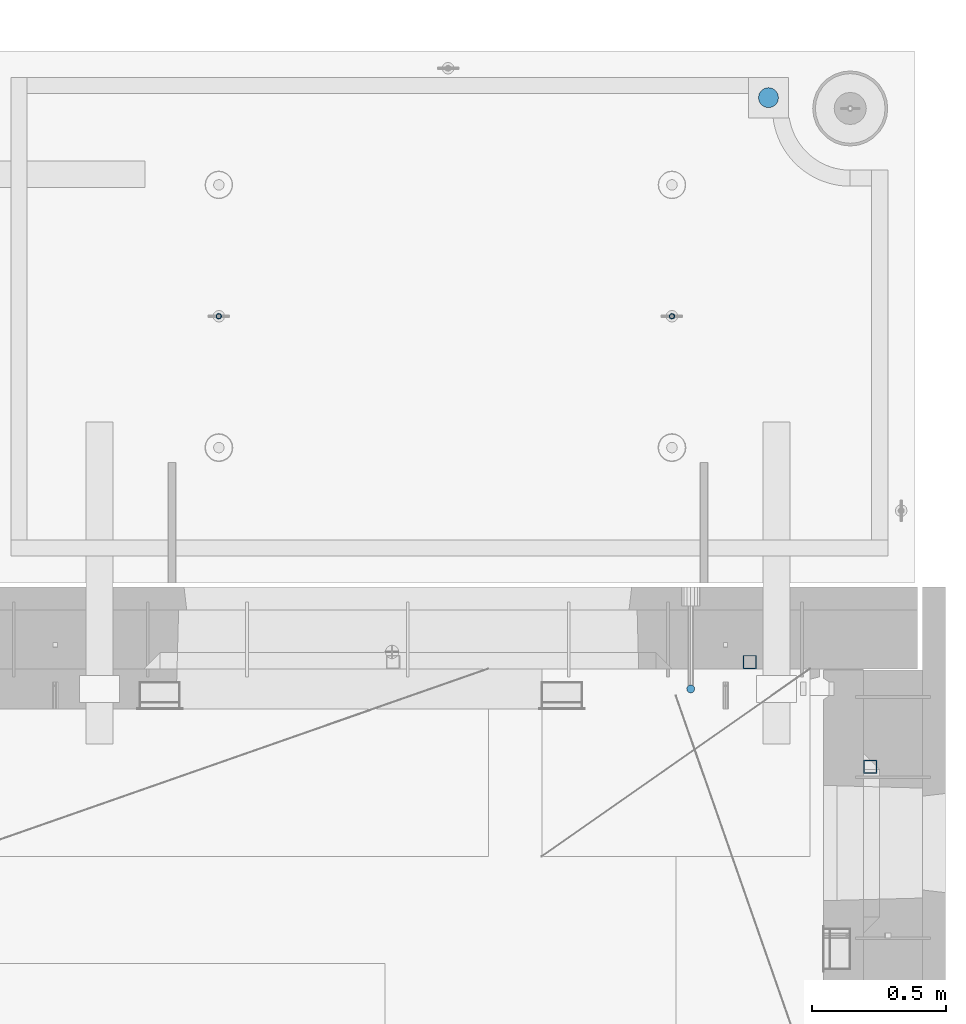
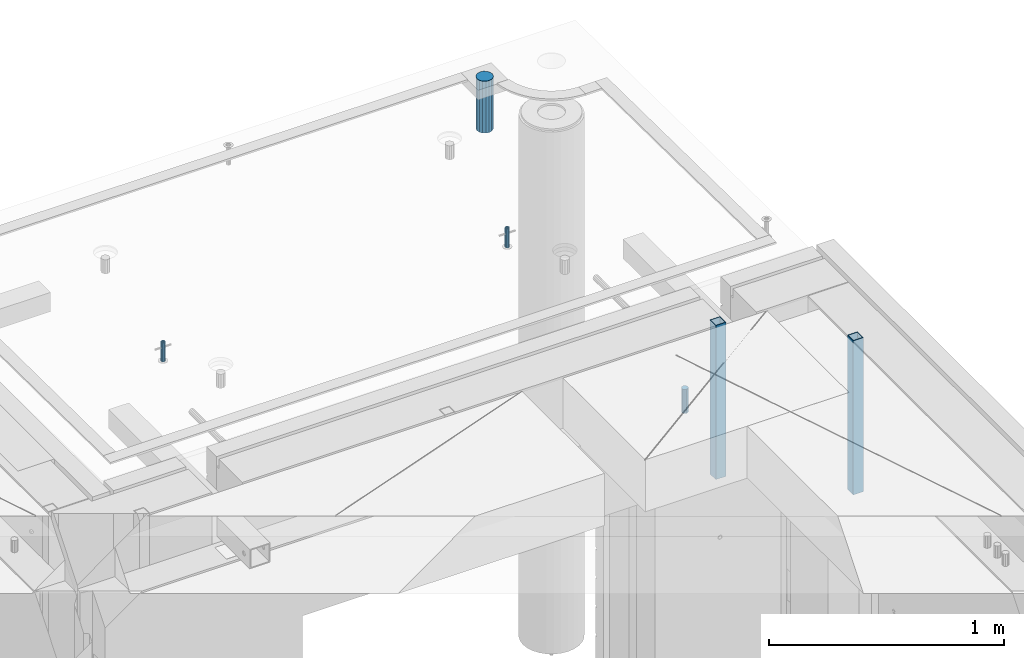
# One storey, part 35 of 334: 6 columns, 7 elements without a shape of their own.
"""IFC2X3 building model written with IfcOpenShell, lengths in millimetres."""

from ifc_helpers import new_model, si_unit, frame, origin_with_axes, place, context, subcontext, project, spatial, faceted_brep, material, type_object, element, aggregate, save


model = new_model("IFC2X3")

# Units and contexts
model_context = context("Model", 3, precision=1e-05, world=origin_with_axes())
body_context = subcontext(model_context, "Body", "Model", "MODEL_VIEW")
ifc_project = project(units=[si_unit("LENGTHUNIT", "METRE", prefix="MILLI"), si_unit("AREAUNIT", "SQUARE_METRE"), si_unit("VOLUMEUNIT", "CUBIC_METRE"), si_unit("MASSUNIT", "GRAM", prefix="KILO"), si_unit("TIMEUNIT", "SECOND"), si_unit("PLANEANGLEUNIT", "RADIAN"), si_unit("SOLIDANGLEUNIT", "STERADIAN"), si_unit("THERMODYNAMICTEMPERATUREUNIT", "DEGREE_CELSIUS"), si_unit("LUMINOUSINTENSITYUNIT", "LUMEN")], contexts=[model_context])

# Site, building, storey
site_placement = place(None, origin_with_axes())
site = spatial("IfcSite", under=ifc_project, at=site_placement, CompositionType="ELEMENT")
building_placement = place(site_placement, origin_with_axes())
building = spatial("IfcBuilding", under=site, at=building_placement, CompositionType="ELEMENT")
storey_placement = place(building_placement, origin_with_axes())
storey = spatial("IfcBuildingStorey", under=building, at=storey_placement, Name="3", CompositionType="ELEMENT", Elevation=0.0)

# Assemblies, columns
assembly_1_placement = place(storey_placement, origin_with_axes())
assembly_1 = element("IfcElementAssembly", 1, at=assembly_1_placement, inside=storey, AssemblyPlace="NOTDEFINED", PredefinedType="REINFORCEMENT_UNIT")
ifc_material_1 = material()
column_type_1 = type_object("IfcColumnType", Name="D30", PredefinedType="NOTDEFINED")
column_1_placement = place(assembly_1_placement, frame((34415.0073334623, 20504.9951872205, 90407.5), z_axis=(0.0, -1.0, 0.0), x_axis=(0.0, 0.0, 1.0)))
column_1 = element("IfcColumn", 2, at=column_1_placement, type_object=column_type_1, material=ifc_material_1, ObjectType="D30", context=body_context, shape_type="Brep", body=[
    faceted_brep([(0.0, -15.0, 0.0), (0.0, -12.9903810567666, -7.5), (125.0, -12.9903810567666, -7.5), (125.0, -15.0, 0.0), (0.0, -7.5, -12.9903810567666), (125.0, -7.5, -12.9903810567666), (0.0, 0.0, -15.0), (125.0, 0.0, -15.0), (0.0, 7.5, -12.9903810567666), (125.0, 7.5, -12.9903810567666), (0.0, 12.9903810567666, -7.5), (125.0, 12.9903810567666, -7.5), (0.0, 15.0, 0.0), (125.0, 15.0, 0.0), (0.0, 12.9903810567666, 7.5), (125.0, 12.9903810567666, 7.5), (0.0, 7.5, 12.9903810567666), (125.0, 7.5, 12.9903810567666), (0.0, 0.0, 15.0), (125.0, 0.0, 15.0), (0.0, -7.5, 12.9903810567666), (125.0, -7.5, 12.9903810567666), (0.0, -12.9903810567666, 7.5), (125.0, -12.9903810567666, 7.5)], [[[0, 1, 2, 3]], [[1, 4, 5, 2]], [[4, 6, 7, 5]], [[6, 8, 9, 7]], [[8, 10, 11, 9]], [[10, 12, 13, 11]], [[12, 14, 15, 13]], [[14, 16, 17, 15]], [[16, 18, 19, 17]], [[18, 20, 21, 19]], [[20, 22, 23, 21]], [[22, 0, 3, 23]], [[5, 7, 9, 11, 13, 15, 17, 19, 21, 23, 3, 2]], [[22, 20, 18, 16, 14, 12, 10, 8, 6, 4, 1, 0]]]),
])
assembly_2_placement = place(assembly_1_placement, origin_with_axes())
assembly_2 = element("IfcElementAssembly", 3, at=assembly_2_placement, Name="Steel Assembly", AssemblyPlace="NOTDEFINED", PredefinedType="RIGID_FRAME")
aggregate(assembly_1, [assembly_2, column_1])
ifc_material_2 = material(Name="STEEL/S355J2")
column_type_2 = type_object("IfcColumnType", Name="50X50X3", PredefinedType="NOTDEFINED")
column_2_placement = place(assembly_2_placement, frame((34635.0, 20605.0, 89940.0), z_axis=(1.0, 0.0, 0.0), x_axis=(0.0, 0.0, 1.0)))
column_2 = element("IfcColumn", 4, at=column_2_placement, type_object=column_type_2, material=ifc_material_2, ObjectType="50X50X3", context=body_context, shape_type="Brep", body=[
    faceted_brep([(0.0, 22.0, -22.0), (0.0, -22.0, -22.0), (800.0, -22.0, -22.0), (800.0, 22.0, -22.0), (0.0, -22.0, 22.0), (800.0, -22.0, 22.0), (0.0, 22.0, 22.0), (800.0, 22.0, 22.0), (0.0, 25.0, -25.0), (0.0, 25.0, 25.0), (800.0, 25.0, 25.0), (800.0, 25.0, -25.0), (0.0, -25.0, 25.0), (800.0, -25.0, 25.0), (0.0, -25.0, -25.0), (800.0, -25.0, -25.0)], [[[0, 1, 2, 3]], [[1, 4, 5, 2]], [[4, 6, 7, 5]], [[6, 0, 3, 7]], [[8, 9, 10, 11]], [[9, 12, 13, 10]], [[12, 14, 15, 13]], [[14, 8, 11, 15]], [[13, 15, 11, 10], [5, 7, 3, 2]], [[14, 12, 9, 8], [6, 4, 1, 0]]]),
])
aggregate(assembly_2, [column_2])

# Assemblies, column
assembly_3_placement = place(storey_placement, origin_with_axes())
assembly_3 = element("IfcElementAssembly", 5, at=assembly_3_placement, inside=storey, AssemblyPlace="NOTDEFINED", PredefinedType="REINFORCEMENT_UNIT")
assembly_4_placement = place(assembly_3_placement, origin_with_axes())
assembly_4 = element("IfcElementAssembly", 6, at=assembly_4_placement, Name="Steel Assembly", AssemblyPlace="NOTDEFINED", PredefinedType="RIGID_FRAME")
aggregate(assembly_3, [assembly_4])
column_3_placement = place(assembly_4_placement, frame((35085.0, 20215.0002861023, 89940.0), z_axis=(0.0, -1.0, 0.0), x_axis=(0.0, 0.0, 1.0)))
column_3 = element("IfcColumn", 7, at=column_3_placement, type_object=column_type_2, material=ifc_material_2, ObjectType="50X50X3", context=body_context, shape_type="Brep", body=[
    faceted_brep([(0.0, 22.0, -22.0), (0.0, -22.0, -22.0), (800.0, -22.0, -22.0), (800.0, 22.0, -22.0), (0.0, -22.0, 22.0), (800.0, -22.0, 22.0), (0.0, 22.0, 22.0), (800.0, 22.0, 22.0), (0.0, 25.0, -25.0), (0.0, 25.0, 25.0), (800.0, 25.0, 25.0), (800.0, 25.0, -25.0), (0.0, -25.0, 25.0), (800.0, -25.0, 25.0), (0.0, -25.0, -25.0), (800.0, -25.0, -25.0)], [[[0, 1, 2, 3]], [[1, 4, 5, 2]], [[4, 6, 7, 5]], [[6, 0, 3, 7]], [[8, 9, 10, 11]], [[9, 12, 13, 10]], [[12, 14, 15, 13]], [[14, 8, 11, 15]], [[13, 15, 11, 10], [5, 7, 3, 2]], [[14, 12, 9, 8], [6, 4, 1, 0]]]),
])
aggregate(assembly_4, [column_3])

# Assemblies, columns
assembly_5_placement = place(storey_placement, origin_with_axes())
assembly_5 = element("IfcElementAssembly", 8, at=assembly_5_placement, inside=storey, AssemblyPlace="NOTDEFINED", PredefinedType="REINFORCEMENT_UNIT")
assembly_6_placement = place(assembly_5_placement, origin_with_axes())
assembly_6 = element("IfcElementAssembly", 9, at=assembly_6_placement, Name="Steel Assembly", AssemblyPlace="NOTDEFINED", PredefinedType="RIGID_FRAME")
ifc_material_3 = material(Name="STEEL/1.4301")
column_type_3 = type_object("IfcColumnType", PredefinedType="NOTDEFINED")
column_4_placement = place(assembly_6_placement, frame((32654.9901431868, 21895.0034426477, 90445.0), z_axis=(0.000321686000089053, -0.999999948259057, 0.0), x_axis=(0.0, 0.0, 1.0)))
column_4 = element("IfcColumn", 10, at=column_4_placement, type_object=column_type_3, material=ifc_material_3, context=body_context, shape_type="Brep", body=[
    faceted_brep([(0.0, -8.0, 0.0), (0.0, -6.92820323027263, 4.0), (100.000000000029, -6.92820323027263, 4.0), (100.000000000029, -7.99999999999636, 0.0), (0.0, -4.0, 6.92820323027627), (100.000000000029, -4.0, 6.92820323027536), (0.0, 0.0, 8.0), (100.000000000029, 3.63797880709171e-12, 8.0), (0.0, 4.0, 6.92820323027627), (100.000000000029, 4.0, 6.92820323027536), (0.0, 6.92820323027263, 4.0), (100.000000000029, 6.92820323027627, 3.99999999999909), (0.0, 8.0, 0.0), (100.000000000029, 8.0, 0.0), (0.0, 6.92820323027263, -4.0), (100.000000000029, 6.92820323027627, -4.00000000000091), (0.0, 4.0, -6.92820323027627), (100.000000000029, 4.00000000000364, -6.92820323027536), (0.0, 0.0, -8.0), (100.000000000029, 3.63797880709171e-12, -8.00000000000091), (0.0, -4.0, -6.92820323027627), (100.000000000029, -3.99999999999636, -6.92820323027627), (0.0, -6.92820323027263, -4.0), (100.000000000029, -6.92820323027263, -4.0), (0.0, -10.4999999999927, -1.45519152283669e-11), (0.0, -9.09326673972828, -5.25000000001455), (100.000000000262, -9.09326673972828, -5.25000000001455), (100.000000000262, -10.4999999999927, -1.45519152283669e-11), (0.0, -5.24999999998545, -9.09326673974283), (100.000000000262, -5.24999999998545, -9.09326673974283), (0.0, 7.27595761418343e-12, -10.5), (100.000000000262, 7.27595761418343e-12, -10.5), (0.0, 5.25000000001455, -9.09326673975738), (100.000000000262, 5.25000000001455, -9.09326673975738), (0.0, 9.09326673975011, -5.25000000001455), (100.000000000262, 9.09326673975011, -5.25000000001455), (0.0, 10.5000000000073, -1.45519152283669e-11), (100.000000000262, 10.5000000000073, -1.45519152283669e-11), (0.0, 9.09326673975011, 5.25), (100.000000000262, 9.09326673975011, 5.25), (0.0, 5.25000000000728, 9.09326673972828), (100.000000000262, 5.25000000000728, 9.09326673972828), (0.0, 1.45519152283669e-11, 10.4999999999854), (100.000000000262, 1.45519152283669e-11, 10.4999999999854), (0.0, -5.24999999999272, 9.09326673972828), (100.000000000262, -5.24999999999272, 9.09326673972828), (0.0, -9.09326673972828, 5.24999999998545), (100.000000000262, -9.09326673972828, 5.24999999998545)], [[[0, 1, 2, 3]], [[1, 4, 5, 2]], [[4, 6, 7, 5]], [[6, 8, 9, 7]], [[8, 10, 11, 9]], [[10, 12, 13, 11]], [[12, 14, 15, 13]], [[14, 16, 17, 15]], [[16, 18, 19, 17]], [[18, 20, 21, 19]], [[20, 22, 23, 21]], [[22, 0, 3, 23]], [[24, 25, 26, 27]], [[25, 28, 29, 26]], [[28, 30, 31, 29]], [[30, 32, 33, 31]], [[32, 34, 35, 33]], [[34, 36, 37, 35]], [[36, 38, 39, 37]], [[38, 40, 41, 39]], [[40, 42, 43, 41]], [[42, 44, 45, 43]], [[44, 46, 47, 45]], [[46, 24, 27, 47]], [[29, 31, 33, 35, 37, 39, 41, 43, 45, 47, 27, 26], [5, 7, 9, 11, 13, 15, 17, 19, 21, 23, 3, 2]], [[46, 44, 42, 40, 38, 36, 34, 32, 30, 28, 25, 24], [22, 20, 18, 16, 14, 12, 10, 8, 6, 4, 1, 0]]]),
])
aggregate(assembly_6, [column_4])
assembly_7_placement = place(assembly_5_placement, origin_with_axes())
assembly_7 = element("IfcElementAssembly", 11, at=assembly_7_placement, Name="Steel Assembly", AssemblyPlace="NOTDEFINED", PredefinedType="RIGID_FRAME")
column_5_placement = place(assembly_7_placement, frame((34345.0001431868, 21895.0034426477, 90445.0), z_axis=(0.000321686000089053, -0.999999948259057, 0.0), x_axis=(0.0, 0.0, 1.0)))
column_5 = element("IfcColumn", 12, at=column_5_placement, type_object=column_type_3, material=ifc_material_3, context=body_context, shape_type="Brep", body=[
    faceted_brep([(0.0, -8.0, 0.0), (0.0, -6.92820323027263, 4.0), (100.000000000029, -6.92820323027263, 4.0), (100.000000000029, -7.99999999999636, 0.0), (0.0, -4.0, 6.92820323027627), (100.000000000029, -4.0, 6.92820323027536), (0.0, 0.0, 8.0), (100.000000000029, 3.63797880709171e-12, 8.0), (0.0, 4.0, 6.92820323027627), (100.000000000029, 4.0, 6.92820323027536), (0.0, 6.92820323027263, 4.0), (100.000000000029, 6.92820323027627, 3.99999999999909), (0.0, 8.0, 0.0), (100.000000000029, 8.0, 0.0), (0.0, 6.92820323027263, -4.0), (100.000000000029, 6.92820323027627, -4.00000000000091), (0.0, 4.0, -6.92820323027627), (100.000000000029, 4.00000000000364, -6.92820323027536), (0.0, 0.0, -8.0), (100.000000000029, 3.63797880709171e-12, -8.00000000000091), (0.0, -4.0, -6.92820323027627), (100.000000000029, -3.99999999999636, -6.92820323027627), (0.0, -6.92820323027263, -4.0), (100.000000000029, -6.92820323027263, -4.0), (0.0, -10.4999999999927, -1.45519152283669e-11), (0.0, -9.09326673972828, -5.25000000001455), (100.000000000262, -9.09326673972828, -5.25000000001455), (100.000000000262, -10.4999999999927, -1.45519152283669e-11), (0.0, -5.24999999998545, -9.09326673974283), (100.000000000262, -5.24999999998545, -9.09326673974283), (0.0, 7.27595761418343e-12, -10.5), (100.000000000262, 7.27595761418343e-12, -10.5), (0.0, 5.25000000001455, -9.09326673975738), (100.000000000262, 5.25000000001455, -9.09326673975738), (0.0, 9.09326673975011, -5.25000000001455), (100.000000000262, 9.09326673975011, -5.25000000001455), (0.0, 10.5000000000073, -1.45519152283669e-11), (100.000000000262, 10.5000000000073, -1.45519152283669e-11), (0.0, 9.09326673975011, 5.25), (100.000000000262, 9.09326673975011, 5.25), (0.0, 5.25000000000728, 9.09326673972828), (100.000000000262, 5.25000000000728, 9.09326673972828), (0.0, 1.45519152283669e-11, 10.4999999999854), (100.000000000262, 1.45519152283669e-11, 10.4999999999854), (0.0, -5.24999999999272, 9.09326673972828), (100.000000000262, -5.24999999999272, 9.09326673972828), (0.0, -9.09326673972828, 5.24999999998545), (100.000000000262, -9.09326673972828, 5.24999999998545)], [[[0, 1, 2, 3]], [[1, 4, 5, 2]], [[4, 6, 7, 5]], [[6, 8, 9, 7]], [[8, 10, 11, 9]], [[10, 12, 13, 11]], [[12, 14, 15, 13]], [[14, 16, 17, 15]], [[16, 18, 19, 17]], [[18, 20, 21, 19]], [[20, 22, 23, 21]], [[22, 0, 3, 23]], [[24, 25, 26, 27]], [[25, 28, 29, 26]], [[28, 30, 31, 29]], [[30, 32, 33, 31]], [[32, 34, 35, 33]], [[34, 36, 37, 35]], [[36, 38, 39, 37]], [[38, 40, 41, 39]], [[40, 42, 43, 41]], [[42, 44, 45, 43]], [[44, 46, 47, 45]], [[46, 24, 27, 47]], [[29, 31, 33, 35, 37, 39, 41, 43, 45, 47, 27, 26], [5, 7, 9, 11, 13, 15, 17, 19, 21, 23, 3, 2]], [[46, 44, 42, 40, 38, 36, 34, 32, 30, 28, 25, 24], [22, 20, 18, 16, 14, 12, 10, 8, 6, 4, 1, 0]]]),
])
aggregate(assembly_7, [column_5])
ifc_material_4 = material()
column_type_4 = type_object("IfcColumnType", Name="D75", PredefinedType="NOTDEFINED")
column_6_placement = place(assembly_5_placement, frame((34704.9998568133, 22710.1651093338, 90440.0), z_axis=(0.9999999949993, 0.000100007000000845, 0.0), x_axis=(0.0, 0.0, 1.0)))
column_6 = element("IfcColumn", 13, at=column_6_placement, type_object=column_type_4, material=ifc_material_4, ObjectType="D75", context=body_context, shape_type="Brep", body=[
    faceted_brep([(0.0, -37.4999999999991, 1.81898940354586e-12), (0.0, -34.6454824691718, -14.3506287136888), (270.0, -34.6454824691718, -14.3506287136888), (270.0, -37.4999999999991, 1.81898940354586e-12), (0.0, -26.5165042944936, -26.5165042944936), (270.0, -26.5165042944936, -26.5165042944936), (0.0, -14.3506287136906, -34.6454824691718), (270.0, -14.3506287136906, -34.6454824691718), (0.0, 9.09494701772928e-13, -37.4999999999982), (270.0, 9.09494701772928e-13, -37.4999999999982), (0.0, 14.3506287136915, -34.6454824691718), (270.0, 14.3506287136915, -34.6454824691718), (0.0, 26.5165042944973, -26.5165042944927), (270.0, 26.5165042944973, -26.5165042944927), (0.0, 34.6454824691746, -14.3506287136897), (270.0, 34.6454824691746, -14.3506287136897), (0.0, 37.5000000000018, 1.81898940354586e-12), (270.0, 37.5000000000018, 1.81898940354586e-12), (0.0, 34.6454824691755, 14.3506287136925), (270.0, 34.6454824691755, 14.3506287136925), (0.0, 26.5165042944964, 26.5165042944973), (270.0, 26.5165042944964, 26.5165042944973), (0.0, 14.3506287136934, 34.6454824691755), (270.0, 14.3506287136934, 34.6454824691755), (0.0, 1.81898940354586e-12, 37.5000000000027), (270.0, 1.81898940354586e-12, 37.5000000000027), (0.0, -14.3506287136897, 34.6454824691746), (270.0, -14.3506287136897, 34.6454824691746), (0.0, -26.5165042944946, 26.5165042944973), (270.0, -26.5165042944946, 26.5165042944973), (0.0, -34.6454824691718, 14.3506287136925), (270.0, -34.6454824691718, 14.3506287136925)], [[[0, 1, 2, 3]], [[1, 4, 5, 2]], [[4, 6, 7, 5]], [[6, 8, 9, 7]], [[8, 10, 11, 9]], [[10, 12, 13, 11]], [[12, 14, 15, 13]], [[14, 16, 17, 15]], [[16, 18, 19, 17]], [[18, 20, 21, 19]], [[20, 22, 23, 21]], [[22, 24, 25, 23]], [[24, 26, 27, 25]], [[26, 28, 29, 27]], [[28, 30, 31, 29]], [[30, 0, 3, 31]], [[5, 7, 9, 11, 13, 15, 17, 19, 21, 23, 25, 27, 29, 31, 3, 2]], [[30, 28, 26, 24, 22, 20, 18, 16, 14, 12, 10, 8, 6, 4, 1, 0]]]),
])
aggregate(assembly_5, [assembly_6, assembly_7, column_6])

save(model, "model.ifc")
